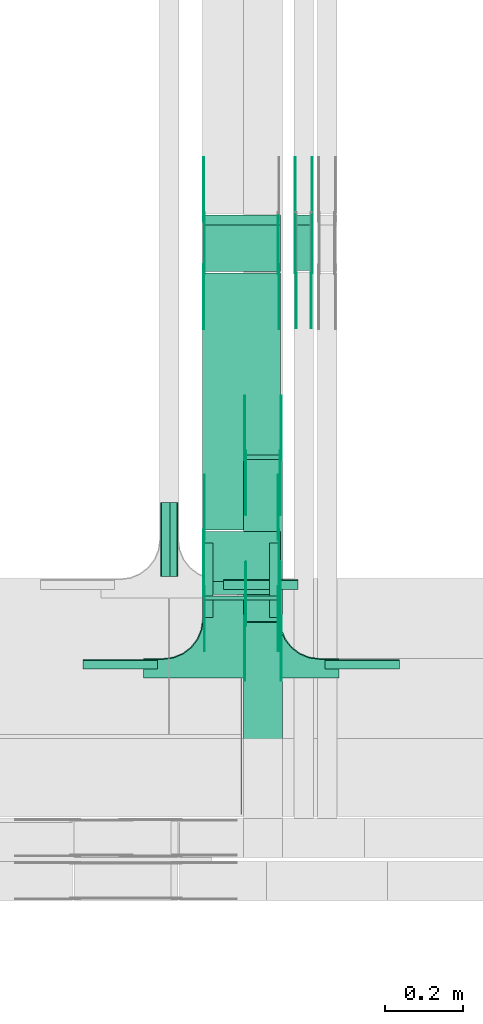
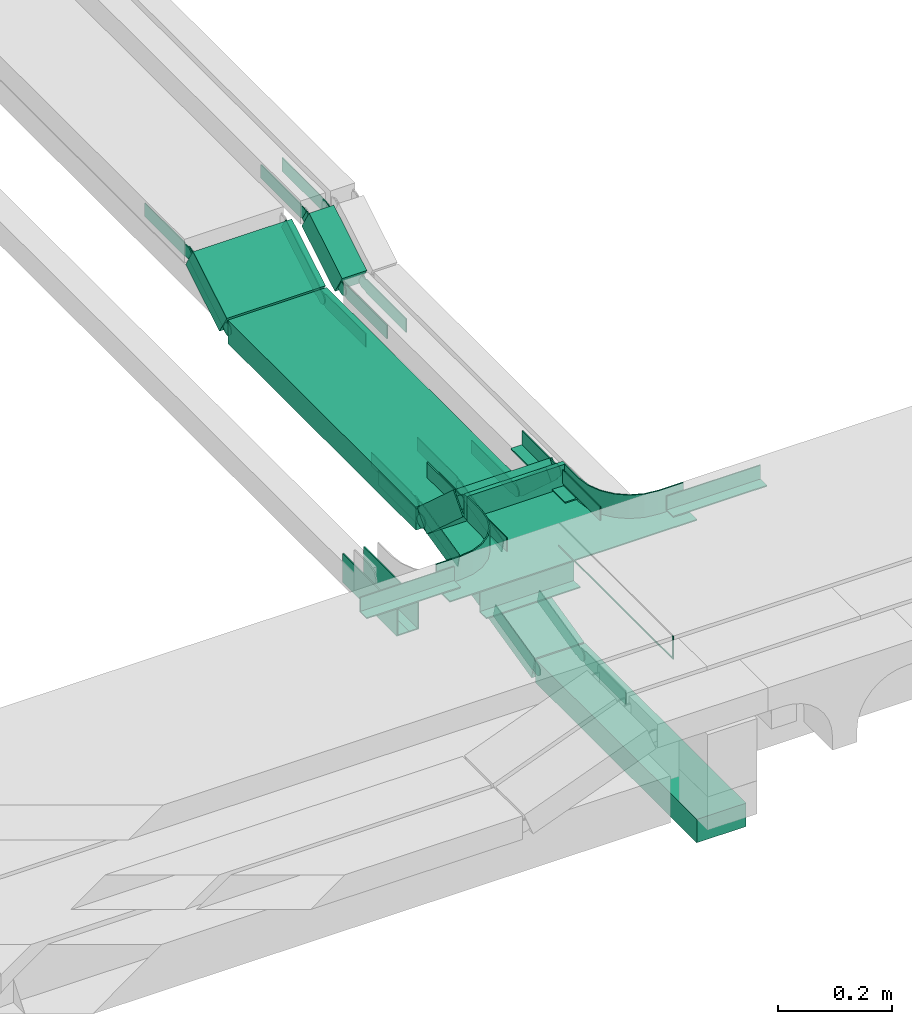
# One storey, part 24 of 28: 36 flow fittings, 7 flow segments.
"""IFC2X3 building model written with IfcOpenShell, lengths in millimetres."""

from ifc_helpers import new_model, entity, si_unit, converted_unit, derived_unit, direction, frame, frame_2d, origin, origin_2d_with_axis, place, context, subcontext, project, spatial, polyline, circle_curve, parameter, trimmed, segment, composite_curve, rectangle, outline, extrude, faceted_brep, source, transform, mapped, material, type_object, type_shapes, element, save


model = new_model("IFC2X3")

# Units and contexts
model_context = context("Model", 3, precision=0.01, world=origin(), true_north=direction((6.12303176911189e-17, 1.0)))
body_context = subcontext(model_context, "Body", "Model", "MODEL_VIEW")
ifc_project = project(units=[si_unit("LENGTHUNIT", "METRE", prefix="MILLI"), si_unit("AREAUNIT", "SQUARE_METRE"), si_unit("VOLUMEUNIT", "CUBIC_METRE"), converted_unit("PLANEANGLEUNIT", "DEGREE", entity("IfcRatioMeasure", 0.0174532925199433), si_unit("PLANEANGLEUNIT", "RADIAN"), dimensions=[0, 0, 0, 0, 0, 0, 0]), si_unit("MASSUNIT", "GRAM", prefix="KILO"), derived_unit("MASSDENSITYUNIT", [(si_unit("MASSUNIT", "GRAM", prefix="KILO"), 1), (si_unit("LENGTHUNIT", "METRE"), -3)]), derived_unit("MOMENTOFINERTIAUNIT", [(si_unit("LENGTHUNIT", "METRE"), 4)]), si_unit("TIMEUNIT", "SECOND"), si_unit("FREQUENCYUNIT", "HERTZ"), si_unit("THERMODYNAMICTEMPERATUREUNIT", "DEGREE_CELSIUS"), derived_unit("THERMALTRANSMITTANCEUNIT", [(si_unit("MASSUNIT", "GRAM", prefix="KILO"), 1), (si_unit("THERMODYNAMICTEMPERATUREUNIT", "KELVIN"), -1), (si_unit("TIMEUNIT", "SECOND"), -3)]), derived_unit("VOLUMETRICFLOWRATEUNIT", [(si_unit("LENGTHUNIT", "METRE"), 3), (si_unit("TIMEUNIT", "SECOND"), -1)]), derived_unit("MASSFLOWRATEUNIT", [(si_unit("MASSUNIT", "GRAM", prefix="KILO"), 1), (si_unit("TIMEUNIT", "SECOND"), -1)]), derived_unit("ROTATIONALFREQUENCYUNIT", [(si_unit("TIMEUNIT", "SECOND"), -1)]), si_unit("ELECTRICCURRENTUNIT", "AMPERE"), si_unit("ELECTRICVOLTAGEUNIT", "VOLT"), si_unit("POWERUNIT", "WATT"), si_unit("FORCEUNIT", "NEWTON", prefix="KILO"), si_unit("ILLUMINANCEUNIT", "LUX"), si_unit("LUMINOUSFLUXUNIT", "LUMEN"), si_unit("LUMINOUSINTENSITYUNIT", "CANDELA"), derived_unit("USERDEFINED", [(si_unit("MASSUNIT", "GRAM", prefix="KILO"), -1), (si_unit("LENGTHUNIT", "METRE"), -2), (si_unit("TIMEUNIT", "SECOND"), 3), (si_unit("LUMINOUSFLUXUNIT", "LUMEN"), 1)]), derived_unit("LINEARVELOCITYUNIT", [(si_unit("LENGTHUNIT", "METRE"), 1), (si_unit("TIMEUNIT", "SECOND"), -1)]), si_unit("PRESSUREUNIT", "PASCAL"), derived_unit("USERDEFINED", [(si_unit("LENGTHUNIT", "METRE"), -2), (si_unit("MASSUNIT", "GRAM", prefix="KILO"), 1), (si_unit("TIMEUNIT", "SECOND"), -2)]), derived_unit("LINEARFORCEUNIT", [(si_unit("MASSUNIT", "GRAM", prefix="KILO"), 1), (si_unit("LENGTHUNIT", "METRE"), 1), (si_unit("TIMEUNIT", "SECOND"), -2), (si_unit("LENGTHUNIT", "METRE"), -1)]), derived_unit("PLANARFORCEUNIT", [(si_unit("MASSUNIT", "GRAM", prefix="KILO"), 1), (si_unit("LENGTHUNIT", "METRE"), 1), (si_unit("TIMEUNIT", "SECOND"), -2), (si_unit("LENGTHUNIT", "METRE"), -2)])], contexts=[model_context])

# Site, building, storey
site_placement = place(None, frame((0.0, -0.00077364408347762, 0.0)))
site = spatial("IfcSite", under=ifc_project, at=site_placement, CompositionType="ELEMENT")
building_placement = place(site_placement, origin())
building = spatial("IfcBuilding", under=site, at=building_placement, CompositionType="ELEMENT")
storey_placement = place(building_placement, origin())
storey = spatial("IfcBuildingStorey", under=building, at=storey_placement, CompositionType="ELEMENT", Elevation=0.0)

# Flow segments
cable_carrier_segment_type = type_object("IfcCableCarrierSegmentType", PredefinedType="CABLETRAYSEGMENT")
flow_segment_1_placement = place(storey_placement, frame((64007.7697248974, 8447.30307535974, 2500.0)))
element("IfcFlowSegment", 1, at=flow_segment_1_placement, inside=storey, type_object=cable_carrier_segment_type, context=body_context, shape_type="SweptSolid", body=[
    extrude(rectangle(XDim=564.4481580588, YDim=99.9999999999946, at=origin_2d_with_axis()), frame((50.0, 282.224079029401, 0.0), z_axis=(0.0, 0.0, 1.0), x_axis=(0.0, -1.0, 0.0)), (0.0, 0.0, 1.0), 49.9999999999995),
])
flow_segment_2_placement = place(storey_placement, frame((64007.7697248974, 9014.64318097609, 2501.67316406556)))
element("IfcFlowSegment", 2, at=flow_segment_2_placement, inside=storey, type_object=cable_carrier_segment_type, context=body_context, shape_type="SweptSolid", body=[
    extrude(rectangle(XDim=49.9999999999991, YDim=426.657179477844, at=frame_2d((0.0, 0.0), x_axis=(0.0, 1.0))), frame((0.0, 213.367766229261, 73.3268359354808), z_axis=(1.0, 0.0, 0.0), x_axis=(0.0, -0.973268623518936, -0.229669733472993)), (0.0, 0.0, 1.0), 99.9999999999945),
])
flow_segment_3_placement = place(storey_placement, frame((63902.1849606245, 9070.00006103515, 2850.0)))
element("IfcFlowSegment", 3, at=flow_segment_3_placement, inside=storey, type_object=cable_carrier_segment_type, context=body_context, shape_type="SweptSolid", body=[
    extrude(rectangle(XDim=9.65396886623574, YDim=200.000000000007, at=frame_2d((1.08268949361445e-12, 8.66862137627322e-12), x_axis=(1.0, 0.0))), frame((100.0, 4.82698443311895, 0.0), z_axis=(0.0, 0.0, 1.0), x_axis=(0.0, -1.0, 0.0)), (0.0, 0.0, 1.0), 50.0000000000005),
])
flow_segment_4_placement = place(storey_placement, frame((63902.1849606245, 9084.0736971523, 2734.08370595551)))
element("IfcFlowSegment", 4, at=flow_segment_4_placement, inside=storey, type_object=cable_carrier_segment_type, context=body_context, shape_type="SweptSolid", body=[
    extrude(rectangle(XDim=49.9999999999991, YDim=170.698727057013, at=frame_2d((1.84741111297626e-13, -2.00728322852228e-13), x_axis=(0.0, 1.0))), frame((0.0, 80.1552030229604, 75.6884920071179), z_axis=(1.0, 0.0, 0.0), x_axis=(0.0, 0.743144825477238, -0.669130606359032)), (0.0, 0.0, 1.0), 200.000000000007),
])
flow_segment_5_placement = place(storey_placement, frame((63902.1849606245, 9248.80377044913, 2719.54439592152)))
element("IfcFlowSegment", 5, at=flow_segment_5_placement, inside=storey, type_object=cable_carrier_segment_type, context=body_context, shape_type="SweptSolid", body=[
    extrude(rectangle(XDim=658.860589157185, YDim=200.000000000007, at=frame_2d((-5.40012479177676e-13, -4.33431068813661e-12), x_axis=(1.0, 0.0))), frame((100.0, 329.430294578593, 1.70118426012778e-09), z_axis=(0.0, 0.0, 1.0), x_axis=(0.0, 1.0, 0.0)), (0.0, 0.0, 1.0), 49.9999999999995),
])
flow_segment_6_placement = place(storey_placement, frame((63902.1849606245, 9911.58167920635, 2727.77239975883)))
element("IfcFlowSegment", 6, at=flow_segment_6_placement, inside=storey, type_object=cable_carrier_segment_type, context=body_context, shape_type="SweptSolid", body=[
    extrude(rectangle(XDim=49.9999999999983, YDim=138.128101267282, at=frame_2d((-1.35003119794419e-13, -2.32702745961433e-13), x_axis=(0.0, 1.0))), frame((0.0, 72.0753977297687, 56.9997982019637), z_axis=(1.0, 0.0, 0.0), x_axis=(0.0, -0.857167300695768, -0.515038074920613)), (0.0, 0.0, 1.0), 200.000000000007),
])
flow_segment_7_placement = place(storey_placement, frame((64137.1849606246, 9914.00421120786, 2729.22800383719)))
element("IfcFlowSegment", 7, at=flow_segment_7_placement, inside=storey, type_object=cable_carrier_segment_type, context=body_context, shape_type="SweptSolid", body=[
    extrude(rectangle(XDim=49.9999999999983, YDim=135.30189452444, at=frame_2d((1.35003119794419e-13, 2.32702745961433e-13), x_axis=(0.0, 1.0))), frame((0.0, 70.8641317274495, 56.2719961613252), z_axis=(1.0, 0.0, 0.0), x_axis=(0.0, 0.857167300702146, 0.515038074909999)), (0.0, 0.0, 1.0), 50.0000000000059),
])

# Flow fittings
ifc_material_1 = material(Name="G")
cable_carrier_fitting_type_1 = type_object("IfcCableCarrierFittingType", PredefinedType="NOTDEFINED", material=ifc_material_1)
shared_shape_1 = source(origin(), body_context, "Body", "SweptSolid", [
    extrude(outline(composite_curve([segment(trimmed(circle_curve(frame_2d((-44.5901162790698, 0.0), x_axis=(1.0, 0.0)), 12.5), [parameter(90.0000000000007)], [parameter(270.0)], True, "PARAMETER"), True, "CONTINUOUS"), segment(polyline([(-44.5901162790697, -12.5), (-33.0901162790698, -12.5)]), True, "CONTINUOUS"), segment(polyline([(-33.0901162790698, -12.5), (-31.2296511627907, -14.5)]), True, "CONTINUOUS"), segment(polyline([(-31.2296511627907, -14.5), (108.90988372093, -14.5)]), True, "CONTINUOUS"), segment(polyline([(108.90988372093, -14.5), (108.90988372093, 14.5)]), True, "CONTINUOUS"), segment(polyline([(108.90988372093, 14.5), (-31.2296511627907, 14.5)]), True, "CONTINUOUS"), segment(polyline([(-31.2296511627907, 14.5), (-33.0901162790698, 12.5)]), True, "CONTINUOUS"), segment(polyline([(-33.0901162790698, 12.5), (-44.5901162790699, 12.5)]), True, "CONTINUOUS")], self_intersect=False)), frame((44.5901162790698, 0.0, 0.0), z_axis=(0.0, 0.0, -1.0), x_axis=(1.0, 0.0, 0.0)), (0.0, 0.0, -1.0), 2.0),
])
type_shapes(cable_carrier_fitting_type_1, [shared_shape_1])
for number, where, z_axis, x_axis in (
    (8, (64012.3097248873, 9439.89533631943, 2625.0), (-1.0, 0.0, 0.0), (0.0, 1.0, 0.0)),
    (9, (64012.3097248873, 9016.12655809127, 2525.0), (-1.0, 0.0, 0.0), (0.0, -1.0, 0.0)),
    (10, (63906.7249606143, 9916.70677138406, 2744.54439592159), (-1.0, 0.0, 0.0), (0.0, -1.0, 0.0)),
    (11, (64182.6449606347, 9919.12930338516, 2746.0), (1.0, 0.0, 0.0), (0.0, 0.857167300697057, 0.515038074918468)),
    (12, (64141.7249606144, 10050.6073824854, 2825.0), (-1.0, 0.0, 0.0), (0.0, 1.0, 0.0)),
    (13, (63906.7249606143, 9091.78608691742, 2875.0), (-1.0, 0.0, 0.0), (0.0, 0.743144825477395, -0.669130606358858)),
    (14, (63906.7249606143, 9236.6717134331, 2744.54439592492), (-1.0, 0.0, 0.0), (0.0, -0.743144825477395, 0.669130606358858)),
    (15, (63906.7249606143, 10050.6073824889, 2825.0), (-1.0, 0.0, 0.0), (0.0, 1.0, 0.0)),
):
    element("IfcFlowFitting", number, at=place(storey_placement, frame(where, z_axis=z_axis, x_axis=x_axis)), inside=storey, type_object=cable_carrier_fitting_type_1, material=ifc_material_1, context=body_context, shape_type="MappedRepresentation", body=[
        mapped(shared_shape_1, transform((0.0, 0.0, 0.0), scale=1.0)),
    ])
cable_carrier_fitting_type_2 = type_object("IfcCableCarrierFittingType", PredefinedType="NOTDEFINED", material=ifc_material_1)
shared_shape_2 = source(origin(), body_context, "Body", "SweptSolid", [
    extrude(outline(composite_curve([segment(trimmed(circle_curve(frame_2d((-44.5901162790697, 0.0), x_axis=(1.0, 0.0)), 12.5), [parameter(90.0000000000007)], [parameter(270.0)], True, "PARAMETER"), True, "CONTINUOUS"), segment(polyline([(-44.5901162790697, -12.5), (-33.0901162790697, -12.5)]), True, "CONTINUOUS"), segment(polyline([(-33.0901162790697, -12.5), (-31.2296511627907, -14.5)]), True, "CONTINUOUS"), segment(polyline([(-31.2296511627907, -14.5), (108.90988372093, -14.5)]), True, "CONTINUOUS"), segment(polyline([(108.90988372093, -14.5), (108.90988372093, 14.5)]), True, "CONTINUOUS"), segment(polyline([(108.90988372093, 14.5), (-31.2296511627907, 14.5)]), True, "CONTINUOUS"), segment(polyline([(-31.2296511627907, 14.5), (-33.0901162790698, 12.5)]), True, "CONTINUOUS"), segment(polyline([(-33.0901162790698, 12.5), (-44.5901162790699, 12.5)]), True, "CONTINUOUS")], self_intersect=False)), frame((44.5901162790697, 0.0, 0.0)), (0.0, 0.0, 1.0), 2.0),
])
type_shapes(cable_carrier_fitting_type_2, [shared_shape_2])
for number, where, z_axis, x_axis in (
    (16, (64103.2297249076, 9439.89533631943, 2625.0), (1.0, 0.0, 0.0), (0.0, 1.0, 0.0)),
    (17, (64103.2297249076, 9016.12655809127, 2525.0), (1.0, 0.0, 0.0), (0.0, -1.0, 0.0)),
    (18, (64097.6449606347, 9916.70677138406, 2744.54439592159), (1.0, 0.0, 0.0), (0.0, -1.0, 0.0)),
    (19, (64141.7249606144, 9919.12930338516, 2746.0), (-1.0, 0.0, 0.0), (0.0, 0.857167300697057, 0.515038074918468)),
    (20, (64182.6449606347, 10050.6073824854, 2825.0), (1.0, 0.0, 0.0), (0.0, 1.0, 0.0)),
    (21, (64097.6449606347, 9091.78608691742, 2875.0), (1.0, 0.0, 0.0), (0.0, 0.743144825477395, -0.669130606358858)),
    (22, (64097.6449606347, 9236.6717134331, 2744.54439592492), (1.0, 0.0, 0.0), (0.0, -0.743144825477395, 0.669130606358858)),
):
    element("IfcFlowFitting", number, at=place(storey_placement, frame(where, z_axis=z_axis, x_axis=x_axis)), inside=storey, type_object=cable_carrier_fitting_type_2, material=ifc_material_1, context=body_context, shape_type="MappedRepresentation", body=[
        mapped(shared_shape_2, transform((0.0, 0.0, 0.0), scale=1.0)),
    ])
cable_carrier_fitting_type_3 = type_object("IfcCableCarrierFittingType", PredefinedType="NOTDEFINED", material=ifc_material_1)
shared_shape_3 = source(origin(), body_context, "Body", "SweptSolid", [
    extrude(outline(composite_curve([segment(trimmed(circle_curve(frame_2d((-44.5901162790698, 0.0), x_axis=(1.0, 0.0)), 12.5), [parameter(90.0000000000007)], [parameter(270.0)], True, "PARAMETER"), True, "CONTINUOUS"), segment(polyline([(-44.5901162790697, -12.5), (-33.0901162790698, -12.5)]), True, "CONTINUOUS"), segment(polyline([(-33.0901162790698, -12.5), (-31.2296511627907, -14.5)]), True, "CONTINUOUS"), segment(polyline([(-31.2296511627907, -14.5), (108.90988372093, -14.5)]), True, "CONTINUOUS"), segment(polyline([(108.90988372093, -14.5), (108.90988372093, 14.5)]), True, "CONTINUOUS"), segment(polyline([(108.90988372093, 14.5), (-31.2296511627907, 14.5)]), True, "CONTINUOUS"), segment(polyline([(-31.2296511627907, 14.5), (-33.0901162790698, 12.5)]), True, "CONTINUOUS"), segment(polyline([(-33.0901162790698, 12.5), (-44.5901162790699, 12.5)]), True, "CONTINUOUS")], self_intersect=False)), frame((44.5901162790698, 0.0, 0.0), z_axis=(0.0, 0.0, -1.0), x_axis=(1.0, 0.0, 0.0)), (0.0, 0.0, -1.0), 2.0),
])
type_shapes(cable_carrier_fitting_type_3, [shared_shape_3])
for number, where, z_axis, x_axis in (
    (23, (64101.2297249076, 9439.89533631945, 2625.0), (1.0, 0.0, 0.0), (0.0, -0.973268623517802, -0.229669733477801)),
    (24, (64101.2297249076, 9016.12655809125, 2525.0), (1.0, 0.0, 0.0), (0.0, 0.973268623517807, 0.229669733477778)),
    (25, (64095.6449606347, 9916.70677138405, 2744.54439592159), (1.0, 0.0, 0.0), (0.0, 0.857167300697282, 0.515038074918093)),
    (26, (64143.7249606144, 9919.12930338517, 2746.0), (-1.0, 0.0, 0.0), (0.0, -1.0, 0.0)),
    (27, (64095.6449606347, 9091.78608691742, 2875.0), (1.0, 0.0, 0.0), (0.0, -1.0, 0.0)),
    (28, (64095.6449606347, 9236.6717134331, 2744.54439592492), (1.0, 0.0, 0.0), (0.0, 1.0, 0.0)),
):
    element("IfcFlowFitting", number, at=place(storey_placement, frame(where, z_axis=z_axis, x_axis=x_axis)), inside=storey, type_object=cable_carrier_fitting_type_3, material=ifc_material_1, context=body_context, shape_type="MappedRepresentation", body=[
        mapped(shared_shape_3, transform((0.0, 0.0, 0.0), scale=1.0)),
    ])
cable_carrier_fitting_type_4 = type_object("IfcCableCarrierFittingType", PredefinedType="NOTDEFINED", material=ifc_material_1)
shared_shape_4 = source(origin(), body_context, "Body", "SweptSolid", [
    extrude(outline(composite_curve([segment(trimmed(circle_curve(frame_2d((-44.5901162790697, 0.0), x_axis=(1.0, 0.0)), 12.5), [parameter(90.0000000000007)], [parameter(270.0)], True, "PARAMETER"), True, "CONTINUOUS"), segment(polyline([(-44.5901162790697, -12.5), (-33.0901162790697, -12.5)]), True, "CONTINUOUS"), segment(polyline([(-33.0901162790697, -12.5), (-31.2296511627907, -14.5)]), True, "CONTINUOUS"), segment(polyline([(-31.2296511627907, -14.5), (108.90988372093, -14.5)]), True, "CONTINUOUS"), segment(polyline([(108.90988372093, -14.5), (108.90988372093, 14.5)]), True, "CONTINUOUS"), segment(polyline([(108.90988372093, 14.5), (-31.2296511627907, 14.5)]), True, "CONTINUOUS"), segment(polyline([(-31.2296511627907, 14.5), (-33.0901162790698, 12.5)]), True, "CONTINUOUS"), segment(polyline([(-33.0901162790698, 12.5), (-44.5901162790699, 12.5)]), True, "CONTINUOUS")], self_intersect=False)), frame((44.5901162790697, 0.0, 0.0)), (0.0, 0.0, 1.0), 2.0),
])
type_shapes(cable_carrier_fitting_type_4, [shared_shape_4])
for number, where, z_axis, x_axis in (
    (29, (64014.3097248873, 9439.89533631945, 2625.0), (-1.0, 0.0, 0.0), (0.0, -0.973268623517802, -0.229669733477801)),
    (30, (64014.3097248873, 9016.12655809125, 2525.0), (-1.0, 0.0, 0.0), (0.0, 0.973268623517807, 0.229669733477778)),
    (31, (63908.7249606143, 9916.70677138405, 2744.54439592159), (-1.0, 0.0, 0.0), (0.0, 0.857167300697282, 0.515038074918093)),
    (32, (64180.6449606347, 9919.12930338517, 2746.0), (1.0, 0.0, 0.0), (0.0, -1.0, 0.0)),
    (33, (63908.7249606143, 9091.78608691742, 2875.0), (-1.0, 0.0, 0.0), (0.0, -1.0, 0.0)),
    (34, (63908.7249606143, 9236.6717134331, 2744.54439592492), (-1.0, 0.0, 0.0), (0.0, 1.0, 0.0)),
    (35, (63908.7249606143, 10050.607382489, 2825.0), (-1.0, 0.0, 0.0), (0.0, -0.857167300695771, -0.515038074920608)),
):
    element("IfcFlowFitting", number, at=place(storey_placement, frame(where, z_axis=z_axis, x_axis=x_axis)), inside=storey, type_object=cable_carrier_fitting_type_4, material=ifc_material_1, context=body_context, shape_type="MappedRepresentation", body=[
        mapped(shared_shape_4, transform((0.0, 0.0, 0.0), scale=1.0)),
    ])
ifc_material_2 = material()
cable_carrier_fitting_type_5 = type_object("IfcCableCarrierFittingType", PredefinedType="NOTDEFINED", material=ifc_material_2)
shared_shape_5 = source(origin(), body_context, "Body", "SweptSolid", [
    extrude(outline(polyline([(-9.16666666666668, -21.5000000000001), (15.8333333333333, -21.5000000000001), (15.8333333333333, -19.0), (-6.66666666666664, -19.0), (-6.66666666666664, 40.5), (-9.16666666666668, 40.5), (-9.16666666666668, -21.5000000000001)])), frame((-95.0, 9.16666666666668, -26.0), z_axis=(1.0, 0.0, 0.0), x_axis=(0.0, 1.0, 0.0)), (0.0, 0.0, 1.0), 190.0),
])
type_shapes(cable_carrier_fitting_type_5, [shared_shape_5])
flow_fitting_1_placement = place(storey_placement, frame((64052.1849606245, 9121.82755701977, 2650.0), z_axis=(0.0, 0.0, 1.0), x_axis=(-1.0, 0.0, 0.0)))
element("IfcFlowFitting", 36, at=flow_fitting_1_placement, inside=storey, type_object=cable_carrier_fitting_type_5, material=ifc_material_2, context=body_context, shape_type="MappedRepresentation", body=[
    mapped(shared_shape_5, transform((0.0, 0.0, 0.0), scale=1.0)),
])
cable_carrier_fitting_type_6 = type_object("IfcCableCarrierFittingType", PredefinedType="NOTDEFINED", material=ifc_material_2)
shared_shape_6 = source(origin(), body_context, "Body", "SweptSolid", [
    extrude(outline(polyline([(-9.16666666666668, -21.5000000000001), (15.8333333333333, -21.5000000000001), (15.8333333333333, -19.0), (-6.66666666666664, -19.0), (-6.66666666666664, 40.5), (-9.16666666666668, 40.5), (-9.16666666666668, -21.5000000000001)])), frame((-95.0, 9.16666666666668, -26.0), z_axis=(1.0, 0.0, 0.0), x_axis=(0.0, 1.0, 0.0)), (0.0, 0.0, 1.0), 190.0),
])
type_shapes(cable_carrier_fitting_type_6, [shared_shape_6])
for number, where, z_axis, x_axis in (
    (37, (63794.6849606245, 9224.32755701977, 2650.0), (0.0, 0.0, 1.0), (0.0, -1.0, 0.0)),
    (38, (63839.6849606245, 9224.32755701977, 2650.0), (0.0, 0.0, 1.0), (0.0, 1.0, 0.0)),
):
    element("IfcFlowFitting", number, at=place(storey_placement, frame(where, z_axis=z_axis, x_axis=x_axis)), inside=storey, type_object=cable_carrier_fitting_type_6, material=ifc_material_2, context=body_context, shape_type="MappedRepresentation", body=[
        mapped(shared_shape_6, transform((0.0, 0.0, 0.0), scale=1.0)),
    ])
cable_carrier_fitting_type_7 = type_object("IfcCableCarrierFittingType", PredefinedType="NOTDEFINED", material=ifc_material_2)
shared_shape_7 = source(origin(), body_context, "Body", "Brep", [
    faceted_brep([(1.0, 197.500000000001, 25.0), (1.0, 197.500000000001, -22.5000000000011), (1.0, -200.0, -22.5000000000011), (1.0, -200.0, -25.0), (1.0, 200.0, -25.0), (1.0, 200.0, 25.0), (-1.0, 197.500000000001, 25.0), (-1.0, 200.0, 25.0), (-1.0, 200.0, -25.0), (-1.0, -200.0, -25.0), (-1.0, -200.0, -22.5000000000011), (-1.0, 197.500000000001, -22.5000000000011)], [[[0, 1, 2, 3, 4, 5]], [[6, 7, 8, 9, 10, 11]], [[1, 0, 6, 11]], [[2, 1, 11, 10]], [[3, 2, 10, 9]], [[4, 3, 9, 8]], [[5, 4, 8, 7]], [[0, 5, 7, 6]]]),
    faceted_brep([(97.4999999999995, -300.0, 25.0), (97.4999999999995, -350.0, 25.0), (100.0, -350.0, 25.0), (100.0, -300.0, 25.0), (103.407417371093, -274.118095489749, 25.0), (113.397459621556, -250.0, 25.0), (129.289321881345, -229.289321881346, 25.0), (150.0, -213.397459621557, 25.0), (174.118095489747, -203.407417371094, 25.0), (200.0, -200.0, 25.0), (250.0, -200.0, 25.0), (250.0, -197.500000000001, 25.0), (200.0, -197.500000000001, 25.0), (173.471047876991, -200.992602805371, 25.0), (148.75, -211.232396112096, 25.0), (127.521554928379, -227.521554928379, 25.0), (111.232396112095, -248.750000000001, 25.0), (100.99260280537, -273.471047876992, 25.0), (-174.118095489753, -203.407417371094, 25.0), (-150.0, -213.397459621557, 25.0), (-129.289321881351, -229.289321881346, 25.0), (-113.397459621562, -250.0, 25.0), (-103.407417371099, -274.118095489749, 25.0), (-100.0, -300.0, 25.0), (-100.0, -350.0, 25.0), (-97.5000000000056, -350.0, 25.0), (-97.5000000000057, -300.0, 25.0), (-100.992602805376, -273.471047876993, 25.0), (-111.232396112101, -248.750000000001, 25.0), (-127.521554928384, -227.52155492838, 25.0), (-148.750000000005, -211.232396112096, 25.0), (-173.471047876997, -200.992602805371, 25.0), (-200.0, -197.500000000001, 25.0), (-250.0, -197.500000000001, 25.0), (-250.0, -200.0, 25.0), (-200.0, -200.0, 25.0), (-200.0, -200.0, -25.0), (-189.212641733723, -201.420182658132, -25.0), (-174.118095489754, -203.407417371094, -25.0), (-200.0, -200.0, -27.5000000000001), (-187.059047744879, -201.703708685552, -27.5000000000001), (-174.118095489753, -203.407417371099, -27.5000000000001), (-162.059047744882, -208.402438496329, -25.0), (-150.0, -213.397459621557, -25.0), (-162.05904774488, -208.40243849633, -27.5000000000001), (-150.0, -213.397459621562, -27.5000000000001), (-139.644660940681, -221.343390751454, -25.0), (-129.289321881351, -229.289321881346, -25.0), (-139.644660940678, -221.343390751456, -27.5000000000001), (-129.28932188135, -229.289321881351, -27.5000000000001), (-113.397459621562, -250.0, -25.0), (-108.402438496332, -262.059047744874, -25.0), (-103.407417371099, -274.118095489748, -25.0), (-113.397459621561, -250.0, -27.5000000000001), (-108.40243849633, -262.059047744879, -27.5000000000001), (-103.407417371099, -274.118095489754, -27.5000000000001), (-101.703708685553, -287.059047744874, -25.0), (-100.0, -300.0, -25.0), (-101.420182658065, -289.21264173423, -27.5000000000001), (-100.0, -300.0, -27.5000000000001), (-121.343390751459, -239.644660940674, -25.0), (-121.343390751456, -239.644660940678, -27.5000000000001), (-100.0, -350.0, -27.5000000000001), (100.0, -350.0, -27.5000000000001), (97.4999999999995, -350.0, -25.0), (-97.5000000000056, -350.0, -25.0), (-97.5000000000056, -300.0, -25.0), (-100.992602805376, -273.471047876993, -25.0), (-111.2323961121, -248.750000000002, -25.0), (-127.521554928384, -227.52155492838, -25.0), (-148.750000000005, -211.232396112096, -25.0), (-173.471047876996, -200.992602805372, -25.0), (-200.0, -197.500000000001, -25.0), (100.0, -300.0, -27.5000000000001), (100.0, -300.0, -25.0), (103.407417371093, -274.11809548975, -25.0), (101.420182658216, -289.212641733042, -25.0), (101.703708685546, -287.059047744881, -27.5000000000001), (103.407417371093, -274.118095489754, -27.5000000000001), (113.397459621555, -250.0, -25.0), (108.402438496325, -262.059047744877, -25.0), (108.402438496324, -262.059047744881, -27.5000000000001), (113.397459621555, -250.0, -27.5000000000001), (121.343390751452, -239.644660940677, -25.0), (129.289321881344, -229.289321881347, -25.0), (121.34339075145, -239.644660940679, -27.5000000000001), (129.289321881345, -229.289321881352, -27.5000000000001), (150.0, -213.397459621557, -25.0), (139.644660940673, -221.343390751456, -25.0), (139.644660940671, -221.343390751457, -27.5000000000001), (150.0, -213.397459621562, -27.5000000000001), (174.118095489747, -203.407417371094, -25.0), (162.059047744874, -208.40243849633, -25.0), (162.059047744873, -208.402438496331, -27.5000000000001), (174.118095489747, -203.407417371099, -27.5000000000001), (187.059047744873, -201.703708685553, -25.0), (200.0, -200.0, -25.0), (189.212641734218, -201.420182658066, -27.5000000000001), (200.0, -200.0, -27.5000000000001), (200.0, -197.500000000001, -25.0), (173.471047876991, -200.992602805371, -25.0), (148.749999999999, -211.232396112096, -25.0), (127.521554928378, -227.52155492838, -25.0), (111.232396112094, -248.750000000001, -25.0), (100.99260280537, -273.471047876993, -25.0), (97.4999999999995, -300.0, -25.0), (-250.0, -197.500000000001, -25.0), (250.0, -197.500000000001, -25.0), (-250.0, -150.0, -25.0), (-250.0, -150.0, -27.5000000000001), (-250.0, -200.0, -27.5000000000001), (250.0, -200.0, -27.5000000000001), (250.0, -150.0, -27.5000000000001), (250.0, -150.0, -25.0)], [[[0, 1, 2, 3, 4, 5, 6, 7, 8, 9, 10, 11, 12, 13, 14, 15, 16, 17]], [[18, 19, 20, 21, 22, 23, 24, 25, 26, 27, 28, 29, 30, 31, 32, 33, 34, 35]], [[18, 35, 36]], [[18, 36, 37]], [[18, 37, 38]], [[37, 36, 39]], [[37, 39, 40]], [[38, 40, 41]], [[37, 40, 38]], [[19, 18, 38]], [[19, 38, 42]], [[19, 42, 43]], [[38, 41, 42]], [[44, 42, 41]], [[42, 44, 43]], [[44, 45, 43]], [[20, 43, 46]], [[19, 43, 20]], [[20, 46, 47]], [[46, 43, 45]], [[46, 45, 48]], [[48, 49, 47]], [[46, 48, 47]], [[22, 21, 50]], [[22, 50, 51]], [[22, 51, 52]], [[50, 53, 51]], [[54, 51, 53]], [[51, 54, 52]], [[54, 55, 52]], [[23, 22, 52]], [[23, 52, 56]], [[23, 56, 57]], [[52, 55, 56]], [[58, 56, 55]], [[58, 59, 57]], [[56, 58, 57]], [[21, 47, 60]], [[20, 47, 21]], [[21, 60, 50]], [[60, 47, 49]], [[60, 49, 61]], [[60, 61, 50]], [[61, 53, 50]], [[24, 23, 57, 59, 62]], [[25, 24, 62, 63, 2, 1, 64, 65]], [[26, 25, 65, 66]], [[27, 26, 66, 67]], [[28, 27, 67, 68]], [[29, 28, 68, 69]], [[30, 29, 69, 70]], [[31, 30, 70, 71]], [[32, 31, 71, 72]], [[3, 2, 63, 73, 74]], [[4, 3, 75]], [[3, 76, 75]], [[3, 74, 76]], [[76, 74, 73]], [[76, 73, 77]], [[75, 77, 78]], [[76, 77, 75]], [[5, 4, 79]], [[4, 80, 79]], [[4, 75, 80]], [[75, 78, 80]], [[81, 80, 78]], [[80, 81, 79]], [[81, 82, 79]], [[5, 79, 83]], [[5, 83, 84]], [[84, 6, 5]], [[83, 79, 82]], [[83, 82, 85]], [[85, 86, 84]], [[83, 85, 84]], [[7, 6, 87]], [[6, 88, 87]], [[6, 84, 88]], [[88, 84, 86]], [[88, 86, 89]], [[88, 89, 87]], [[89, 90, 87]], [[8, 7, 91]], [[7, 92, 91]], [[7, 87, 92]], [[87, 90, 92]], [[93, 92, 90]], [[92, 93, 91]], [[93, 94, 91]], [[8, 91, 95]], [[8, 95, 96]], [[8, 96, 9]], [[91, 94, 95]], [[97, 95, 94]], [[97, 98, 96]], [[95, 97, 96]], [[13, 12, 99, 100]], [[14, 13, 100, 101]], [[15, 14, 101, 102]], [[102, 103, 16, 15]], [[17, 16, 103, 104]], [[104, 105, 0, 17]], [[1, 0, 105, 64]], [[33, 32, 72, 106]], [[12, 11, 107, 99]], [[34, 33, 106, 108, 109, 110]], [[35, 34, 110, 39, 36]], [[10, 9, 96, 98, 111]], [[10, 111, 112, 113, 107, 11]], [[107, 113, 108, 106, 72, 71, 70, 69, 68, 67, 66, 65, 64, 105, 104, 103, 102, 101, 100, 99]], [[110, 109, 112, 111, 98, 97, 94, 93, 90, 89, 86, 85, 82, 81, 78, 77, 73, 63, 62, 59, 58, 55, 54, 53, 61, 49, 48, 45, 44, 41, 40, 39]], [[108, 113, 112, 109]]]),
])
type_shapes(cable_carrier_fitting_type_7, [shared_shape_7])
flow_fitting_2_placement = place(storey_placement, frame((64002.1849606245, 8720.00006103515, 2875.0), z_axis=(0.0, 0.0, 1.0), x_axis=(-1.0, 0.0, 0.0)))
element("IfcFlowFitting", 39, at=flow_fitting_2_placement, inside=storey, type_object=cable_carrier_fitting_type_7, material=ifc_material_2, context=body_context, shape_type="MappedRepresentation", body=[
    mapped(shared_shape_7, transform((0.0, 0.0, 0.0), scale=1.0)),
])
cable_carrier_fitting_type_8 = type_object("IfcCableCarrierFittingType", PredefinedType="NOTDEFINED", material=ifc_material_2)
shared_shape_8 = source(origin(), body_context, "Body", "SweptSolid", [
    extrude(outline(polyline([(-9.16666666666668, -11.5000000000001), (15.8333333333333, -11.5000000000001), (15.8333333333333, -9.0), (-6.66666666666664, -9.0), (-6.66666666666664, 20.5), (-9.16666666666668, 20.5), (-9.16666666666668, -11.5000000000001)])), frame((-95.0, 9.16666666666668, -11.0), z_axis=(1.0, 0.0, 0.0), x_axis=(0.0, 1.0, 0.0)), (0.0, 0.0, 1.0), 190.0),
])
type_shapes(cable_carrier_fitting_type_8, [shared_shape_8])
for number, where, z_axis, x_axis in (
    (40, (64312.1849606245, 8917.50006103515, 2875.0), (0.0, 0.0, 1.0), (-1.0, 0.0, 0.0)),
    (41, (63904.6849606245, 9120.00006103515, 2875.0), (0.0, 0.0, 1.0), (0.0, -1.0, 0.0)),
    (42, (64099.6849606245, 9120.00006103515, 2875.0), (0.0, 0.0, 1.0), (0.0, 1.0, 0.0)),
):
    element("IfcFlowFitting", number, at=place(storey_placement, frame(where, z_axis=z_axis, x_axis=x_axis)), inside=storey, type_object=cable_carrier_fitting_type_8, material=ifc_material_2, context=body_context, shape_type="MappedRepresentation", body=[
        mapped(shared_shape_8, transform((0.0, 0.0, 0.0), scale=1.0)),
    ])
cable_carrier_fitting_type_9 = type_object("IfcCableCarrierFittingType", PredefinedType="NOTDEFINED", material=ifc_material_2)
shared_shape_9 = source(origin(), body_context, "Body", "SweptSolid", [
    extrude(outline(polyline([(-11.5000000000001, -9.16666666666668), (20.5, -9.16666666666668), (20.5, -6.66666666666664), (-9.0, -6.66666666666664), (-9.0, 15.8333333333333), (-11.5000000000001, 15.8333333333333), (-11.5000000000001, -9.16666666666668)])), frame((-95.0, -9.16666666666668, -11.0), z_axis=(1.0, 0.0, 0.0), x_axis=(0.0, 0.0, 1.0)), (0.0, 0.0, 1.0), 190.0),
])
type_shapes(cable_carrier_fitting_type_9, [shared_shape_9])
flow_fitting_3_placement = place(storey_placement, frame((63692.1849606245, 8917.50006103515, 2875.0)))
element("IfcFlowFitting", 43, at=flow_fitting_3_placement, inside=storey, type_object=cable_carrier_fitting_type_9, material=ifc_material_2, context=body_context, shape_type="MappedRepresentation", body=[
    mapped(shared_shape_9, transform((0.0, 0.0, 0.0), scale=1.0)),
])

save(model, "model.ifc")
